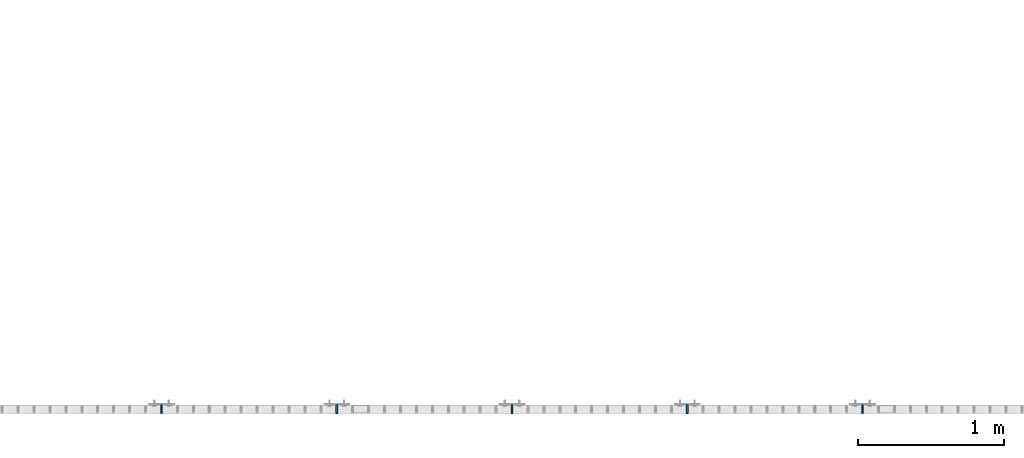
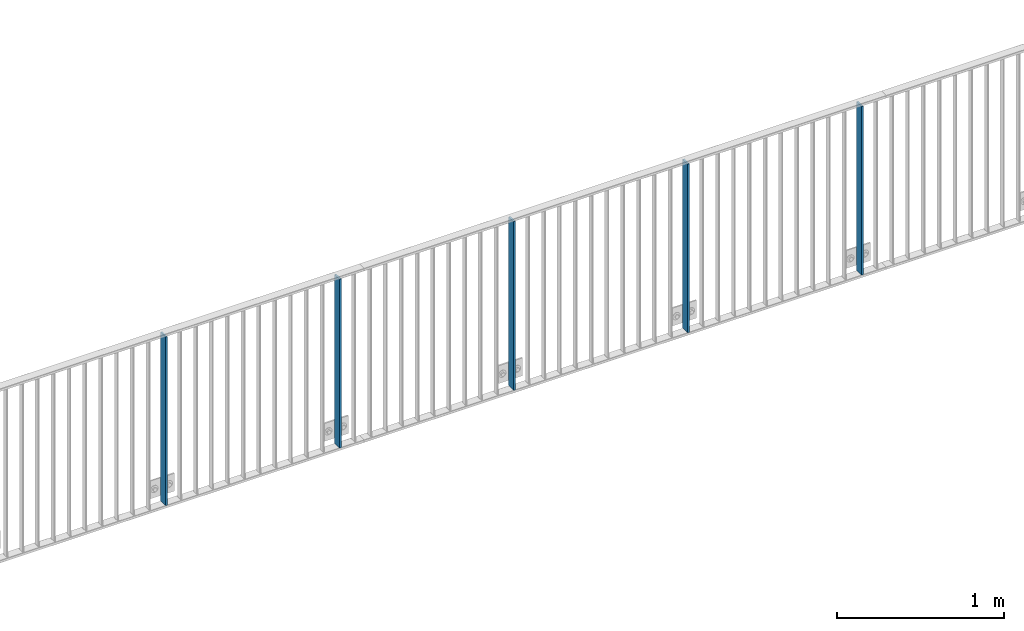
# One storey, part 43 of 156: 5 plates, 2 elements without a shape of their own.
"""IFC2X3 building model written with IfcOpenShell, lengths in millimetres."""

from ifc_helpers import new_model, si_unit, frame, origin_with_axes, origin_2d_with_axis, place, context, subcontext, project, spatial, rectangle, extrude, material, type_object, element, aggregate, save


model = new_model("IFC2X3")

# Units and contexts
model_context = context("Model", 3, precision=1e-05, world=origin_with_axes())
body_context = subcontext(model_context, "Body", "Model", "MODEL_VIEW")
ifc_project = project(units=[si_unit("LENGTHUNIT", "METRE", prefix="MILLI"), si_unit("AREAUNIT", "SQUARE_METRE"), si_unit("VOLUMEUNIT", "CUBIC_METRE"), si_unit("MASSUNIT", "GRAM", prefix="KILO"), si_unit("TIMEUNIT", "SECOND"), si_unit("PLANEANGLEUNIT", "RADIAN"), si_unit("SOLIDANGLEUNIT", "STERADIAN"), si_unit("THERMODYNAMICTEMPERATUREUNIT", "DEGREE_CELSIUS"), si_unit("LUMINOUSINTENSITYUNIT", "LUMEN")], contexts=[model_context])

# Site, building, storey
site_placement = place(None, origin_with_axes())
site = spatial("IfcSite", under=ifc_project, at=site_placement, CompositionType="ELEMENT")
building_placement = place(site_placement, origin_with_axes())
building = spatial("IfcBuilding", under=site, at=building_placement, Name="Undefined", CompositionType="ELEMENT")
storey_placement = place(building_placement, origin_with_axes())
storey = spatial("IfcBuildingStorey", under=building, at=storey_placement, Name="Undefined", CompositionType="ELEMENT", Elevation=0.0)

# Assembly, plates
assembly_1_placement = place(storey_placement, origin_with_axes())
assembly_1 = element("IfcElementAssembly", 1, at=assembly_1_placement, inside=storey, AssemblyPlace="NOTDEFINED", PredefinedType="RIGID_FRAME")
ifc_material = material(Name="STEEL/S235JR")
plate_type = type_object("IfcPlateType", PredefinedType="NOTDEFINED")
plate_1_placement = place(assembly_1_placement, frame((39399.999999999, 8480.0020977057, 3980.00000000003), z_axis=(0.0, 1.0, 0.0), x_axis=(0.0, 0.0, -1.0)))
plate_1 = element("IfcPlate", 2, at=plate_1_placement, type_object=plate_type, material=ifc_material, context=body_context, shape_type="SweptSolid", body=[
    extrude(rectangle(XDim=12.0, YDim=60.0, at=origin_2d_with_axis()), frame((1230.0, 0.0, 0.0), z_axis=(-1.0, 0.0, 0.0), x_axis=(0.0, -1.0, 0.0)), (0.0, 0.0, 1.0), 1230.0),
])
plate_2_placement = place(assembly_1_placement, frame((38199.999999999, 8480.0020977057, 3980.00000000003), z_axis=(0.0, 1.0, 0.0), x_axis=(0.0, 0.0, -1.0)))
plate_2 = element("IfcPlate", 3, at=plate_2_placement, type_object=plate_type, material=ifc_material, context=body_context, shape_type="SweptSolid", body=[
    extrude(rectangle(XDim=12.0, YDim=60.0, at=origin_2d_with_axis()), frame((1230.0, 0.0, 0.0), z_axis=(-1.0, 0.0, 0.0), x_axis=(0.0, -1.0, 0.0)), (0.0, 0.0, 1.0), 1230.0),
])
plate_3_placement = place(assembly_1_placement, frame((36999.999999999, 8480.0020977057, 3980.00000000003), z_axis=(0.0, 1.0, 0.0), x_axis=(0.0, 0.0, -1.0)))
plate_3 = element("IfcPlate", 4, at=plate_3_placement, type_object=plate_type, material=ifc_material, context=body_context, shape_type="SweptSolid", body=[
    extrude(rectangle(XDim=12.0, YDim=60.0, at=origin_2d_with_axis()), frame((1230.0, 0.0, 0.0), z_axis=(-1.0, 0.0, 0.0), x_axis=(0.0, -1.0, 0.0)), (0.0, 0.0, 1.0), 1230.0),
])
aggregate(assembly_1, [plate_1, plate_2, plate_3])

assembly_2_placement = place(storey_placement, origin_with_axes())
assembly_2 = element("IfcElementAssembly", 5, at=assembly_2_placement, inside=storey, AssemblyPlace="NOTDEFINED", PredefinedType="RIGID_FRAME")
plate_4_placement = place(assembly_2_placement, frame((35799.999999999, 8480.0020977057, 3980.00000000003), z_axis=(0.0, 1.0, 0.0), x_axis=(0.0, 0.0, -1.0)))
plate_4 = element("IfcPlate", 6, at=plate_4_placement, type_object=plate_type, material=ifc_material, context=body_context, shape_type="SweptSolid", body=[
    extrude(rectangle(XDim=12.0, YDim=60.0, at=origin_2d_with_axis()), frame((1230.0, 0.0, 0.0), z_axis=(-1.0, 0.0, 0.0), x_axis=(0.0, -1.0, 0.0)), (0.0, 0.0, 1.0), 1230.0),
])
plate_5_placement = place(assembly_2_placement, frame((34599.999999999, 8480.0020977057, 3980.00000000003), z_axis=(0.0, 1.0, 0.0), x_axis=(0.0, 0.0, -1.0)))
plate_5 = element("IfcPlate", 7, at=plate_5_placement, type_object=plate_type, material=ifc_material, context=body_context, shape_type="SweptSolid", body=[
    extrude(rectangle(XDim=12.0, YDim=60.0, at=origin_2d_with_axis()), frame((1230.0, 0.0, 0.0), z_axis=(-1.0, 0.0, 0.0), x_axis=(0.0, -1.0, 0.0)), (0.0, 0.0, 1.0), 1230.0),
])
aggregate(assembly_2, [plate_4, plate_5])

save(model, "model.ifc")
